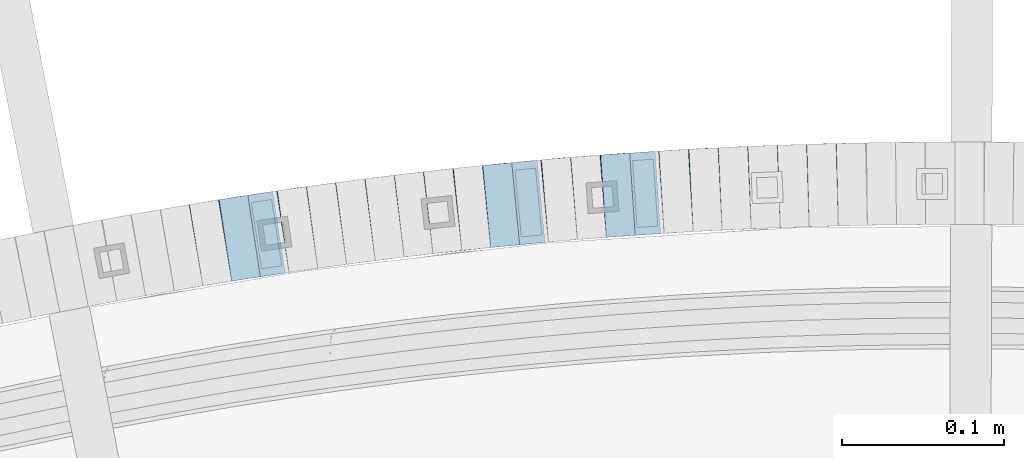
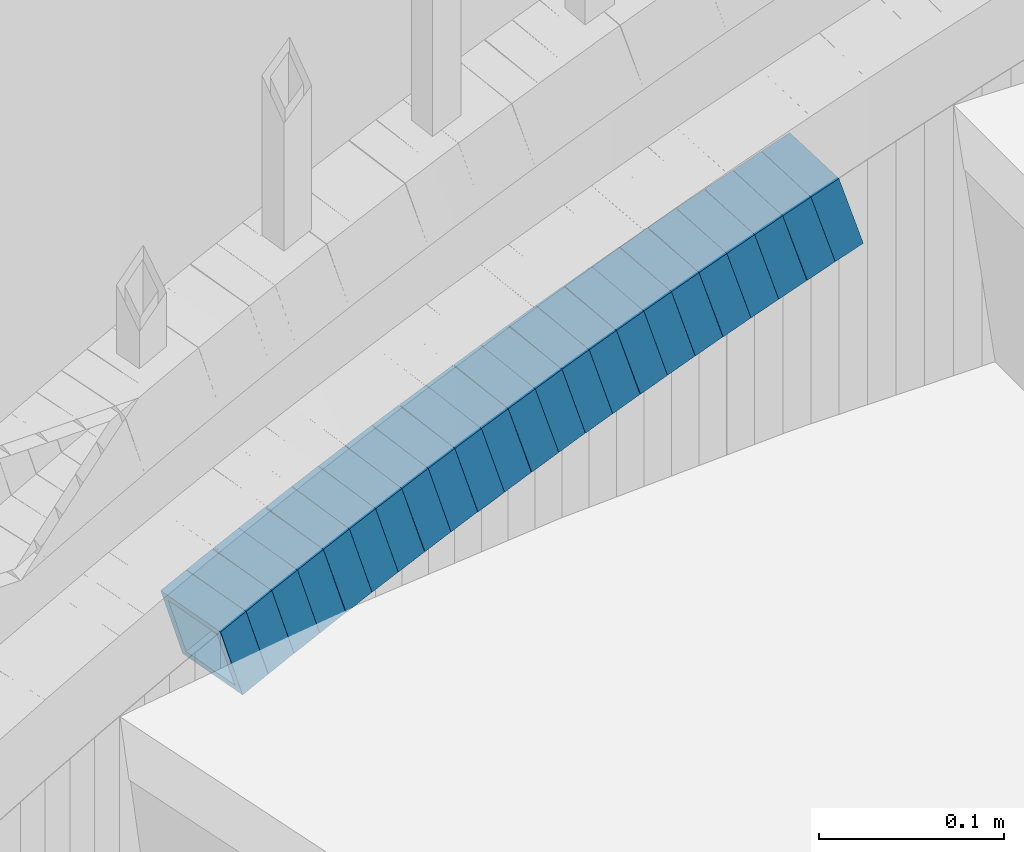
# One storey, part 817 of 975: 23 beams.
"""IFC2X3 building model written with IfcOpenShell, lengths in millimetres."""

from ifc_helpers import new_model, si_unit, frame, origin_with_axes, place, context, subcontext, project, spatial, faceted_brep, material, type_object, element, save


model = new_model("IFC2X3")

# Units and contexts
model_context = context("Model", 3, precision=1e-05, world=origin_with_axes())
body_context = subcontext(model_context, "Body", "Model", "MODEL_VIEW")
ifc_project = project(units=[si_unit("LENGTHUNIT", "METRE", prefix="MILLI"), si_unit("AREAUNIT", "SQUARE_METRE"), si_unit("VOLUMEUNIT", "CUBIC_METRE"), si_unit("MASSUNIT", "GRAM", prefix="KILO"), si_unit("TIMEUNIT", "SECOND"), si_unit("PLANEANGLEUNIT", "RADIAN"), si_unit("SOLIDANGLEUNIT", "STERADIAN"), si_unit("THERMODYNAMICTEMPERATUREUNIT", "DEGREE_CELSIUS"), si_unit("LUMINOUSINTENSITYUNIT", "LUMEN")], contexts=[model_context])

# Site, building, storey
site_placement = place(None, origin_with_axes())
site = spatial("IfcSite", under=ifc_project, at=site_placement, CompositionType="ELEMENT")
building_placement = place(site_placement, origin_with_axes())
building = spatial("IfcBuilding", under=site, at=building_placement, Name="Undefined", CompositionType="ELEMENT")
storey_placement = place(building_placement, origin_with_axes())
storey = spatial("IfcBuildingStorey", under=building, at=storey_placement, Name="Undefined", CompositionType="ELEMENT", Elevation=0.0)

# Beams
ifc_material = material()
beam_type = type_object("IfcBeamType", Name="HSS2X2X.188_TUBES", PredefinedType="NOTDEFINED")
beam_1_placement = place(storey_placement, frame((34651.9456916336, 6273.00545372927, 1013.93551160437), z_axis=(0.0335007382158728, -0.999438692736574, 7.27269480194081e-11), x_axis=(-0.950823807192718, -0.0318711890064746, -0.308088161062478)))
element("IfcBeam", 1, at=beam_1_placement, inside=storey, type_object=beam_type, material=ifc_material, Name="WALL", ObjectType="HSS2X2X.188_TUBES", context=body_context, shape_type="Brep", body=[
    faceted_brep([(0.0, 20.6374999999753, -20.6375000000298), (0.0, -20.6375000000153, -20.6375000000153), (18.8332159191086, -20.6374999999916, -20.6375000000153), (18.8332159190923, 20.6375000000062, -20.6375000000335), (0.0, -20.6374999999825, 20.6375000000335), (18.8332159191377, -20.6375000000062, 20.6375000000335), (0.0, 20.6375000000116, 20.6375000000189), (18.8332159191141, 20.6374999999916, 20.6375000000116), (0.0, 25.3999999999724, -25.4000000000342), (0.0, 25.400000000016, 25.4000000000196), (18.8332159191159, 25.3999999999905, 25.4000000000124), (18.8332159190886, 25.4000000000069, -25.4000000000415), (0.0, -25.399999999976, 25.4000000000378), (18.8332159191395, -25.4000000000069, 25.4000000000378), (0.0, -25.400000000016, -25.4000000000196), (18.8332159191104, -25.3999999999905, -25.400000000016)], [[[0, 1, 2, 3]], [[1, 4, 5, 2]], [[4, 6, 7, 5]], [[6, 0, 3, 7]], [[8, 9, 10, 11]], [[9, 12, 13, 10]], [[12, 14, 15, 13]], [[14, 8, 11, 15]], [[13, 15, 11, 10], [5, 7, 3, 2]], [[14, 12, 9, 8], [6, 4, 1, 0]]]),
])
beam_2_placement = place(storey_placement, frame((34669.8027725868, 6273.46496530648, 1019.60911814612), z_axis=(0.0280788118240962, -0.99960571243193, -6.01653482590336e-11), x_axis=(-0.952021405617887, -0.0267421739892645, -0.304860786877666)))
element("IfcBeam", 2, at=beam_2_placement, inside=storey, type_object=beam_type, material=ifc_material, Name="WALL", ObjectType="HSS2X2X.188_TUBES", context=body_context, shape_type="Brep", body=[
    faceted_brep([(0.0, 20.6374999999753, -20.6375000000298), (0.0, -20.6375000000153, -20.6375000000153), (18.6959888745805, -20.6374999999771, -20.6375000000407), (18.6959888746751, 20.637499999988, -20.6374999999716), (0.0, -20.6374999999825, 20.6375000000335), (18.6959888746969, -20.6375000000135, 20.6375000000371), (0.0, 20.6375000000116, 20.6375000000189), (18.6959888747988, 20.6374999999498, 20.6375000001062), (0.0, 25.3999999999724, -25.4000000000342), (0.0, 25.400000000016, 25.4000000000196), (18.695988874817, 25.3999999999414, 25.4000000001215), (18.6959888746678, 25.3999999999887, -25.399999999976), (0.0, -25.399999999976, 25.4000000000378), (18.6959888747042, -25.4000000000124, 25.4000000000378), (0.0, -25.400000000016, -25.4000000000196), (18.695988874555, -25.3999999999687, -25.4000000000597)], [[[0, 1, 2, 3]], [[1, 4, 5, 2]], [[4, 6, 7, 5]], [[6, 0, 3, 7]], [[8, 9, 10, 11]], [[9, 12, 13, 10]], [[12, 14, 15, 13]], [[14, 8, 11, 15]], [[13, 15, 11, 10], [5, 7, 3, 2]], [[14, 12, 9, 8], [6, 4, 1, 0]]]),
])
beam_3_placement = place(storey_placement, frame((34633.7787524898, 6272.43910339028, 1008.09576019962), z_axis=(0.0390762776090341, -0.999236230592257, 1.98711632037885e-10), x_axis=(-0.952195014016826, -0.0372366770006501, -0.303212937005408)))
element("IfcBeam", 3, at=beam_3_placement, inside=storey, type_object=beam_type, material=ifc_material, Name="WALL", ObjectType="HSS2X2X.188_TUBES", context=body_context, shape_type="Brep", body=[
    faceted_brep([(0.0, 20.6374999999753, -20.6375000000298), (0.0, -20.6375000000153, -20.6375000000153), (18.8047866246379, -20.6374999999916, -20.6375000000298), (18.8047866247143, 20.6374999999844, -20.6374999999643), (0.0, -20.6374999999825, 20.6375000000335), (18.8047866247107, -20.6375000000189, 20.6375000000407), (0.0, 20.6375000000116, 20.6375000000189), (18.8047866247907, 20.6374999999589, 20.6375000001026), (0.0, 25.3999999999724, -25.4000000000342), (0.0, 25.400000000016, 25.4000000000196), (18.8047866248016, 25.3999999999542, 25.4000000001142), (18.8047866247143, 25.3999999999851, -25.3999999999651), (0.0, -25.399999999976, 25.4000000000378), (18.8047866247107, -25.4000000000196, 25.4000000000415), (0.0, -25.400000000016, -25.4000000000196), (18.8047866246197, -25.3999999999887, -25.4000000000378)], [[[0, 1, 2, 3]], [[1, 4, 5, 2]], [[4, 6, 7, 5]], [[6, 0, 3, 7]], [[8, 9, 10, 11]], [[9, 12, 13, 10]], [[12, 14, 15, 13]], [[14, 8, 11, 15]], [[13, 15, 11, 10], [5, 7, 3, 2]], [[14, 12, 9, 8], [6, 4, 1, 0]]]),
])
beam_4_placement = place(storey_placement, frame((34615.766485447, 6271.77941453297, 1002.40773709342), z_axis=(0.044898496675909, -0.998991554016471, 2.07617631531321e-10), x_axis=(-0.951490800323589, -0.0427636310145619, -0.304690874103617)))
element("IfcBeam", 4, at=beam_4_placement, inside=storey, type_object=beam_type, material=ifc_material, Name="WALL", ObjectType="HSS2X2X.188_TUBES", context=body_context, shape_type="Brep", body=[
    faceted_brep([(0.0, 20.6374999999753, -20.6375000000298), (0.0, -20.6375000000153, -20.6375000000153), (18.7112265765609, -20.6375000000062, -20.6374999999862), (18.7112265765645, 20.6374999999898, -20.6374999999789), (0.0, -20.6374999999825, 20.6375000000335), (18.7112265765209, -20.6374999999916, 20.6374999999607), (0.0, 20.6375000000116, 20.6375000000189), (18.7112265765245, 20.6375000000025, 20.6374999999716), (0.0, 25.3999999999724, -25.4000000000342), (0.0, 25.400000000016, 25.4000000000196), (18.7112265765172, 25.4000000000051, 25.3999999999614), (18.7112265765718, 25.3999999999887, -25.3999999999724), (0.0, -25.399999999976, 25.4000000000378), (18.7112265765136, -25.3999999999905, 25.3999999999542), (0.0, -25.400000000016, -25.4000000000196), (18.7112265765682, -25.4000000000069, -25.3999999999796)], [[[0, 1, 2, 3]], [[1, 4, 5, 2]], [[4, 6, 7, 5]], [[6, 0, 3, 7]], [[8, 9, 10, 11]], [[9, 12, 13, 10]], [[12, 14, 15, 13]], [[14, 8, 11, 15]], [[13, 15, 11, 10], [5, 7, 3, 2]], [[14, 12, 9, 8], [6, 4, 1, 0]]]),
])
beam_5_placement = place(storey_placement, frame((34597.9106893534, 6271.01822015742, 996.733904844898), z_axis=(0.0502158966098432, -0.998738386028929, -1.26572444969497e-10), x_axis=(-0.950220743318218, -0.04777646201599, -0.307892755103149)))
element("IfcBeam", 5, at=beam_5_placement, inside=storey, type_object=beam_type, material=ifc_material, Name="WALL", ObjectType="HSS2X2X.188_TUBES", context=body_context, shape_type="Brep", body=[
    faceted_brep([(0.0, 20.6374999999753, -20.6375000000298), (0.0, -20.6375000000153, -20.6375000000153), (18.8433011969464, -20.6374999999898, -20.6375000000226), (18.8433011969719, 20.6375000000007, -20.6374999999862), (0.0, -20.6374999999825, 20.6375000000335), (18.8433011969828, -20.6375000000044, 20.6375000000189), (0.0, 20.6375000000116, 20.6375000000189), (18.8433011970155, 20.6374999999862, 20.6375000000517), (0.0, 25.3999999999724, -25.4000000000342), (0.0, 25.400000000016, 25.4000000000196), (18.8433011970228, 25.3999999999833, 25.4000000000597), (18.8433011969719, 25.4000000000015, -25.3999999999869), (0.0, -25.399999999976, 25.4000000000378), (18.8433011969864, -25.4000000000051, 25.4000000000196), (0.0, -25.400000000016, -25.4000000000196), (18.8433011969391, -25.3999999999869, -25.4000000000269)], [[[0, 1, 2, 3]], [[1, 4, 5, 2]], [[4, 6, 7, 5]], [[6, 0, 3, 7]], [[8, 9, 10, 11]], [[9, 12, 13, 10]], [[12, 14, 15, 13]], [[14, 8, 11, 15]], [[13, 15, 11, 10], [5, 7, 3, 2]], [[14, 12, 9, 8], [6, 4, 1, 0]]]),
])
beam_6_placement = place(storey_placement, frame((34579.6270192323, 6270.18615367943, 990.905724300762), z_axis=(0.0616800884415425, -0.998095970681098, 1.47142372952658e-10), x_axis=(-0.950716893774198, -0.058752167986055, -0.304443049927697)))
element("IfcBeam", 6, at=beam_6_placement, inside=storey, type_object=beam_type, material=ifc_material, Name="WALL", ObjectType="HSS2X2X.188_TUBES", context=body_context, shape_type="Brep", body=[
    faceted_brep([(0.0, 20.6374999999753, -20.6375000000298), (0.0, -20.6375000000153, -20.6375000000153), (18.724849799155, -20.6375000000171, -20.6374999999425), (18.7248497991204, 20.6374999999989, -20.6375000000007), (0.0, -20.6374999999825, 20.6375000000335), (18.7248497991168, -20.6374999999953, 20.6375000000007), (0.0, 20.6375000000116, 20.6375000000189), (18.724849799084, 20.6375000000226, 20.6374999999498), (0.0, 25.3999999999724, -25.4000000000342), (0.0, 25.400000000016, 25.4000000000196), (18.7248497990731, 25.4000000000269, 25.399999999936), (18.7248497991204, 25.3999999999978, -25.3999999999978), (0.0, -25.399999999976, 25.4000000000378), (18.7248497991186, -25.3999999999942, 25.4000000000051), (0.0, -25.400000000016, -25.4000000000196), (18.7248497991604, -25.4000000000233, -25.3999999999323)], [[[0, 1, 2, 3]], [[1, 4, 5, 2]], [[4, 6, 7, 5]], [[6, 0, 3, 7]], [[8, 9, 10, 11]], [[9, 12, 13, 10]], [[12, 14, 15, 13]], [[14, 8, 11, 15]], [[13, 15, 11, 10], [5, 7, 3, 2]], [[14, 12, 9, 8], [6, 4, 1, 0]]]),
])
beam_7_placement = place(storey_placement, frame((34561.6506361358, 6269.11512934846, 985.19247535075), z_axis=(0.0668889670804565, -0.997760425193799, 2.13868815990281e-11), x_axis=(-0.950917720470324, -0.0637486740315266, -0.302806201149754)))
element("IfcBeam", 7, at=beam_7_placement, inside=storey, type_object=beam_type, material=ifc_material, Name="WALL", ObjectType="HSS2X2X.188_TUBES", context=body_context, shape_type="Brep", body=[
    faceted_brep([(0.0, 20.6374999999753, -20.6375000000298), (0.0, -20.6375000000153, -20.6375000000153), (18.8225928075335, -20.6374999999935, -20.6375000000298), (18.8225928075699, 20.6374999999898, -20.6374999999825), (0.0, -20.6374999999825, 20.6375000000335), (18.8225928075772, -20.637500000008, 20.6375000000226), (0.0, 20.6375000000116, 20.6375000000189), (18.8225928076135, 20.6374999999753, 20.6375000000698), (0.0, 25.3999999999724, -25.4000000000342), (0.0, 25.400000000016, 25.4000000000196), (18.8225928076281, 25.3999999999705, 25.4000000000815), (18.8225928075663, 25.3999999999905, -25.3999999999796), (0.0, -25.399999999976, 25.4000000000378), (18.8225928075808, -25.4000000000087, 25.4000000000233), (0.0, -25.400000000016, -25.4000000000196), (18.8225928075226, -25.3999999999905, -25.4000000000378)], [[[0, 1, 2, 3]], [[1, 4, 5, 2]], [[4, 6, 7, 5]], [[6, 0, 3, 7]], [[8, 9, 10, 11]], [[9, 12, 13, 10]], [[12, 14, 15, 13]], [[14, 8, 11, 15]], [[13, 15, 11, 10], [5, 7, 3, 2]], [[14, 12, 9, 8], [6, 4, 1, 0]]]),
])
beam_8_placement = place(storey_placement, frame((34543.9023718288, 6267.9282507441, 979.544478576939), z_axis=(0.0672630522607651, -0.997735276413822, -1.4846455087536e-10), x_axis=(-0.948851018029333, -0.0639674840019559, -0.309176174009509)))
element("IfcBeam", 8, at=beam_8_placement, inside=storey, type_object=beam_type, material=ifc_material, Name="WALL", ObjectType="HSS2X2X.188_TUBES", context=body_context, shape_type="Brep", body=[
    faceted_brep([(0.0, 20.6374999999753, -20.6375000000298), (0.0, -20.6375000000153, -20.6375000000153), (18.7555325170906, -20.6374999999916, -20.6374999999971), (18.7555325171452, 20.637499999988, -20.6374999999571), (0.0, -20.6374999999825, 20.6375000000335), (18.7555325170615, -20.6374999999844, 20.6374999999716), (0.0, 20.6375000000116, 20.6375000000189), (18.7555325171015, 20.6374999999953, 20.637500000008), (0.0, 25.3999999999724, -25.4000000000342), (0.0, 25.400000000016, 25.4000000000196), (18.7555325171015, 25.399999999996, 25.4000000000051), (18.7555325171488, 25.3999999999851, -25.3999999999505), (0.0, -25.399999999976, 25.4000000000378), (18.755532517047, -25.3999999999814, 25.3999999999578), (0.0, -25.400000000016, -25.4000000000196), (18.7555325170979, -25.3999999999924, -25.3999999999978)], [[[0, 1, 2, 3]], [[1, 4, 5, 2]], [[4, 6, 7, 5]], [[6, 0, 3, 7]], [[8, 9, 10, 11]], [[9, 12, 13, 10]], [[12, 14, 15, 13]], [[14, 8, 11, 15]], [[13, 15, 11, 10], [5, 7, 3, 2]], [[14, 12, 9, 8], [6, 4, 1, 0]]]),
])
beam_9_placement = place(storey_placement, frame((34525.6847734434, 6266.78503410578, 973.703086094591), z_axis=(0.0784095351745709, -0.996921232993714, -1.11433109850623e-10), x_axis=(-0.949701466907197, -0.074695620992727, -0.304117884970335)))
element("IfcBeam", 9, at=beam_9_placement, inside=storey, type_object=beam_type, material=ifc_material, Name="WALL", ObjectType="HSS2X2X.188_TUBES", context=body_context, shape_type="Brep", body=[
    faceted_brep([(0.0, 20.6374999999753, -20.6375000000298), (0.0, -20.6375000000153, -20.6375000000153), (18.7416648140024, -20.6375000000153, -20.6374999999825), (18.7416648139188, 20.6375000000189, -20.6375000000298), (0.0, -20.6374999999825, 20.6375000000335), (18.7416648140097, -20.6375000000189, 20.6375000000226), (0.0, 20.6375000000116, 20.6375000000189), (18.741664813926, 20.6375000000153, 20.6374999999753), (0.0, 25.3999999999724, -25.4000000000342), (0.0, 25.400000000016, 25.4000000000196), (18.7416648139224, 25.4000000000196, 25.3999999999687), (18.7416648139042, 25.4000000000233, -25.4000000000378), (0.0, -25.399999999976, 25.4000000000378), (18.7416648140133, -25.4000000000215, 25.4000000000269), (0.0, -25.400000000016, -25.4000000000196), (18.7416648140133, -25.4000000000196, -25.399999999976)], [[[0, 1, 2, 3]], [[1, 4, 5, 2]], [[4, 6, 7, 5]], [[6, 0, 3, 7]], [[8, 9, 10, 11]], [[9, 12, 13, 10]], [[12, 14, 15, 13]], [[14, 8, 11, 15]], [[13, 15, 11, 10], [5, 7, 3, 2]], [[14, 12, 9, 8], [6, 4, 1, 0]]]),
])
beam_10_placement = place(storey_placement, frame((34507.7368106391, 6265.41622528425, 968.002069082572), z_axis=(0.0839720319663757, -0.996468111806614, -5.50892309547635e-12), x_axis=(-0.949309706342206, -0.0799980090288675, -0.30399243410962)))
element("IfcBeam", 10, at=beam_10_placement, inside=storey, type_object=beam_type, material=ifc_material, Name="WALL", ObjectType="HSS2X2X.188_TUBES", context=body_context, shape_type="Brep", body=[
    faceted_brep([(0.0, 20.6374999999753, -20.6375000000298), (0.0, -20.6375000000153, -20.6375000000153), (18.7547327359644, -20.6374999999844, -20.6375000000553), (18.7547327359898, 20.6375000000171, -20.6375000000335), (0.0, -20.6374999999825, 20.6375000000335), (18.7547327360044, -20.6374999999953, 20.6374999999898), (0.0, 20.6375000000116, 20.6375000000189), (18.7547327360262, 20.6375000000062, 20.6375000000116), (0.0, 25.3999999999724, -25.4000000000342), (0.0, 25.400000000016, 25.4000000000196), (18.7547327360371, 25.4000000000033, 25.4000000000124), (18.7547327359898, 25.4000000000178, -25.4000000000342), (0.0, -25.399999999976, 25.4000000000378), (18.7547327360044, -25.399999999996, 25.3999999999869), (0.0, -25.400000000016, -25.4000000000196), (18.7547327359498, -25.3999999999814, -25.4000000000597)], [[[0, 1, 2, 3]], [[1, 4, 5, 2]], [[4, 6, 7, 5]], [[6, 0, 3, 7]], [[8, 9, 10, 11]], [[9, 12, 13, 10]], [[12, 14, 15, 13]], [[14, 8, 11, 15]], [[13, 15, 11, 10], [5, 7, 3, 2]], [[14, 12, 9, 8], [6, 4, 1, 0]]]),
])
beam_11_placement = place(storey_placement, frame((34489.6652361008, 6263.98248508332, 962.312352926034), z_axis=(0.0956052464452733, -0.995419327144163, 1.37664756039158e-10), x_axis=(-0.947907534808342, -0.0910419669816018, -0.305258358938281)))
element("IfcBeam", 11, at=beam_11_placement, inside=storey, type_object=beam_type, material=ifc_material, Name="WALL", ObjectType="HSS2X2X.188_TUBES", context=body_context, shape_type="Brep", body=[
    faceted_brep([(0.0, 20.6374999999753, -20.6375000000298), (0.0, -20.6375000000153, -20.6375000000153), (18.6689581926366, -20.6374999999953, -20.6374999999916), (18.6689581926476, 20.6375000000062, -20.6374999999935), (0.0, -20.6374999999825, 20.6375000000335), (18.6689581927276, -20.6375000000116, 20.6374999999862), (0.0, 20.6375000000116, 20.6375000000189), (18.6689581927312, 20.6374999999862, 20.6374999999844), (0.0, 25.3999999999724, -25.4000000000342), (0.0, 25.400000000016, 25.4000000000196), (18.6689581927458, 25.3999999999833, 25.3999999999814), (18.6689581926366, 25.4000000000087, -25.3999999999905), (0.0, -25.399999999976, 25.4000000000378), (18.6689581927385, -25.4000000000142, 25.3999999999851), (0.0, -25.400000000016, -25.4000000000196), (18.6689581926257, -25.3999999999887, -25.3999999999869)], [[[0, 1, 2, 3]], [[1, 4, 5, 2]], [[4, 6, 7, 5]], [[6, 0, 3, 7]], [[8, 9, 10, 11]], [[9, 12, 13, 10]], [[12, 14, 15, 13]], [[14, 8, 11, 15]], [[13, 15, 11, 10], [5, 7, 3, 2]], [[14, 12, 9, 8], [6, 4, 1, 0]]]),
])
beam_12_placement = place(storey_placement, frame((34472.062156533, 6262.28758067493, 956.639241073771), z_axis=(0.0950730065790558, -0.995470302630882, 1.98357952285733e-10), x_axis=(-0.946902283782594, -0.090434487979261, -0.308541193929169)))
element("IfcBeam", 12, at=beam_12_placement, inside=storey, type_object=beam_type, material=ifc_material, Name="WALL", ObjectType="HSS2X2X.188_TUBES", context=body_context, shape_type="Brep", body=[
    faceted_brep([(0.0, 20.6374999999753, -20.6375000000298), (0.0, -20.6375000000153, -20.6375000000153), (18.8047866246379, -20.6374999999916, -20.6375000000298), (18.8047866247143, 20.6374999999844, -20.6374999999643), (0.0, -20.6374999999825, 20.6375000000335), (18.8047866247107, -20.6375000000189, 20.6375000000407), (0.0, 20.6375000000116, 20.6375000000189), (18.8047866247907, 20.6374999999589, 20.6375000001026), (0.0, 25.3999999999724, -25.4000000000342), (0.0, 25.400000000016, 25.4000000000196), (18.8047866248016, 25.3999999999542, 25.4000000001142), (18.8047866247143, 25.3999999999851, -25.3999999999651), (0.0, -25.399999999976, 25.4000000000378), (18.8047866247107, -25.4000000000196, 25.4000000000415), (0.0, -25.400000000016, -25.4000000000196), (18.8047866246197, -25.3999999999887, -25.4000000000378)], [[[0, 1, 2, 3]], [[1, 4, 5, 2]], [[4, 6, 7, 5]], [[6, 0, 3, 7]], [[8, 9, 10, 11]], [[9, 12, 13, 10]], [[12, 14, 15, 13]], [[14, 8, 11, 15]], [[13, 15, 11, 10], [5, 7, 3, 2]], [[14, 12, 9, 8], [6, 4, 1, 0]]]),
])
beam_13_placement = place(storey_placement, frame((34453.842627824, 6260.63203614672, 950.797322509361), z_axis=(0.10613862675189, -0.994351342288641, 2.283063622599e-10), x_axis=(-0.947478931466088, -0.101135391943018, -0.303406174829077)))
element("IfcBeam", 13, at=beam_13_placement, inside=storey, type_object=beam_type, material=ifc_material, Name="WALL", ObjectType="HSS2X2X.188_TUBES", context=body_context, shape_type="Brep", body=[
    faceted_brep([(0.0, 20.6374999999753, -20.6375000000298), (0.0, -20.6375000000153, -20.6375000000153), (18.7853666454903, -20.6375000000535, -20.6375000000326), (18.785366645363, 20.6374999999862, -20.6375000000044), (0.0, -20.6374999999825, 20.6375000000335), (18.785366645352, -20.6375000000007, 20.6374999999989), (0.0, 20.6375000000116, 20.6375000000189), (18.7853666453102, 20.6375000000025, 20.6374999999753), (0.0, 25.3999999999724, -25.4000000000342), (0.0, 25.400000000016, 25.4000000000196), (18.7853666452065, 25.4000000000451, 25.4000000000351), (18.7853666453739, 25.3999999999833, -25.400000000006), (0.0, -25.399999999976, 25.4000000000378), (18.7853666497213, -25.399999993424, 25.3999999995158), (0.0, -25.400000000016, -25.4000000000196), (18.7853666455194, -25.4000000000633, -25.4000000000406)], [[[0, 1, 2, 3]], [[1, 4, 5, 2]], [[4, 6, 7, 5]], [[6, 0, 3, 7]], [[8, 9, 10, 11]], [[9, 12, 13, 10]], [[12, 14, 15, 13]], [[14, 8, 11, 15]], [[13, 15, 11, 10], [5, 7, 3, 2]], [[14, 12, 9, 8], [6, 4, 1, 0]]]),
])
beam_14_placement = place(storey_placement, frame((34436.0659098705, 6258.739161128, 945.109792112416), z_axis=(0.106731467305151, -0.994287882802003, -2.14448618862662e-10), x_axis=(-0.946930338465762, -0.101647889050003, -0.30494366815003)))
element("IfcBeam", 14, at=beam_14_placement, inside=storey, type_object=beam_type, material=ifc_material, Name="WALL", ObjectType="HSS2X2X.188_TUBES", context=body_context, shape_type="Brep", body=[
    faceted_brep([(0.0, 20.6374999999753, -20.6375000000298), (0.0, -20.6375000000153, -20.6375000000153), (18.6895692834223, -20.637499999988, -20.6374999999862), (18.6895692834369, 20.6374999999953, -20.6374999999534), (0.0, -20.6374999999825, 20.6375000000335), (18.6895692833914, -20.637499999988, 20.6374999999789), (0.0, 20.6375000000116, 20.6375000000189), (18.6895692834078, 20.6374999999953, 20.637500000008), (0.0, 25.3999999999724, -25.4000000000342), (0.0, 25.400000000016, 25.4000000000196), (18.6895692834059, 25.3999999999924, 25.4000000000087), (18.6895692834423, 25.3999999999942, -25.3999999999432), (0.0, -25.399999999976, 25.4000000000378), (18.6895692833878, -25.3999999999869, 25.3999999999687), (0.0, -25.400000000016, -25.4000000000196), (18.6895692834241, -25.3999999999869, -25.3999999999833)], [[[0, 1, 2, 3]], [[1, 4, 5, 2]], [[4, 6, 7, 5]], [[6, 0, 3, 7]], [[8, 9, 10, 11]], [[9, 12, 13, 10]], [[12, 14, 15, 13]], [[14, 8, 11, 15]], [[13, 15, 11, 10], [5, 7, 3, 2]], [[14, 12, 9, 8], [6, 4, 1, 0]]]),
])
beam_15_placement = place(storey_placement, frame((34418.0443524869, 6256.88452171945, 939.394547887718), z_axis=(0.117164953610445, -0.99311246777264, -1.14560293695831e-10), x_axis=(-0.946406940559033, -0.111654750947977, -0.303062896858783)))
element("IfcBeam", 15, at=beam_15_placement, inside=storey, type_object=beam_type, material=ifc_material, Name="WALL", ObjectType="HSS2X2X.188_TUBES", context=body_context, shape_type="Brep", body=[
    faceted_brep([(0.0, 20.6374999999753, -20.6375000000298), (0.0, -20.6375000000153, -20.6375000000153), (18.8066477608099, -20.6374999999862, -20.6375000000116), (18.8066477608172, 20.6375000000062, -20.6374999999971), (0.0, -20.6374999999825, 20.6375000000335), (18.8066477608463, -20.6375000000062, 20.6375000000407), (0.0, 20.6375000000116, 20.6375000000189), (18.8066477608536, 20.6374999999844, 20.637500000048), (0.0, 25.3999999999724, -25.4000000000342), (0.0, 25.400000000016, 25.4000000000196), (18.8066477608591, 25.3999999999814, 25.400000000056), (18.8066477608154, 25.4000000000051, -25.4000000000015), (0.0, -25.399999999976, 25.4000000000378), (18.8066477608518, -25.4000000000087, 25.4000000000451), (0.0, -25.400000000016, -25.4000000000196), (18.8066477608081, -25.3999999999851, -25.4000000000196)], [[[0, 1, 2, 3]], [[1, 4, 5, 2]], [[4, 6, 7, 5]], [[6, 0, 3, 7]], [[8, 9, 10, 11]], [[9, 12, 13, 10]], [[12, 14, 15, 13]], [[14, 8, 11, 15]], [[13, 15, 11, 10], [5, 7, 3, 2]], [[14, 12, 9, 8], [6, 4, 1, 0]]]),
])
beam_16_placement = place(storey_placement, frame((34400.2373783662, 6254.83243716997, 933.745022917291), z_axis=(0.123344664337586, -0.992363891815622, -2.0636423414544e-10), x_axis=(-0.943721538367308, -0.117298722045678, -0.309242086120394)))
element("IfcBeam", 16, at=beam_16_placement, inside=storey, type_object=beam_type, material=ifc_material, Name="WALL", ObjectType="HSS2X2X.188_TUBES", context=body_context, shape_type="Brep", body=[
    faceted_brep([(0.0, 20.6374999999753, -20.6375000000298), (0.0, -20.6375000000153, -20.6375000000153), (18.7555325170906, -20.6374999999916, -20.6374999999971), (18.7555325171452, 20.637499999988, -20.6374999999571), (0.0, -20.6374999999825, 20.6375000000335), (18.7555325170615, -20.6374999999844, 20.6374999999716), (0.0, 20.6375000000116, 20.6375000000189), (18.7555325171015, 20.6374999999953, 20.637500000008), (0.0, 25.3999999999724, -25.4000000000342), (0.0, 25.400000000016, 25.4000000000196), (18.7555325171015, 25.399999999996, 25.4000000000051), (18.7555325171488, 25.3999999999851, -25.3999999999505), (0.0, -25.399999999976, 25.4000000000378), (18.755532517047, -25.3999999999814, 25.3999999999578), (0.0, -25.400000000016, -25.4000000000196), (18.7555325170979, -25.3999999999924, -25.3999999999978)], [[[0, 1, 2, 3]], [[1, 4, 5, 2]], [[4, 6, 7, 5]], [[6, 0, 3, 7]], [[8, 9, 10, 11]], [[9, 12, 13, 10]], [[12, 14, 15, 13]], [[14, 8, 11, 15]], [[13, 15, 11, 10], [5, 7, 3, 2]], [[14, 12, 9, 8], [6, 4, 1, 0]]]),
])
beam_17_placement = place(storey_placement, frame((34382.265108553, 6252.64149160385, 927.903858770483), z_axis=(0.128860134810282, -0.991662778194622, -6.80902303429321e-11), x_axis=(-0.944661915133941, -0.122752678017422, -0.304213159043171)))
element("IfcBeam", 17, at=beam_17_placement, inside=storey, type_object=beam_type, material=ifc_material, Name="WALL", ObjectType="HSS2X2X.188_TUBES", context=body_context, shape_type="Brep", body=[
    faceted_brep([(0.0, 20.6374999999753, -20.6375000000298), (0.0, -20.6375000000153, -20.6375000000153), (18.7416648140024, -20.6375000000153, -20.6374999999825), (18.7416648139188, 20.6375000000189, -20.6375000000298), (0.0, -20.6374999999825, 20.6375000000335), (18.7416648140097, -20.6375000000189, 20.6375000000226), (0.0, 20.6375000000116, 20.6375000000189), (18.741664813926, 20.6375000000153, 20.6374999999753), (0.0, 25.3999999999724, -25.4000000000342), (0.0, 25.400000000016, 25.4000000000196), (18.7416648139224, 25.4000000000196, 25.3999999999687), (18.7416648139042, 25.4000000000233, -25.4000000000378), (0.0, -25.399999999976, 25.4000000000378), (18.7416648140133, -25.4000000000215, 25.4000000000269), (0.0, -25.400000000016, -25.4000000000196), (18.7416648140133, -25.4000000000196, -25.399999999976)], [[[0, 1, 2, 3]], [[1, 4, 5, 2]], [[4, 6, 7, 5]], [[6, 0, 3, 7]], [[8, 9, 10, 11]], [[9, 12, 13, 10]], [[12, 14, 15, 13]], [[14, 8, 11, 15]], [[13, 15, 11, 10], [5, 7, 3, 2]], [[14, 12, 9, 8], [6, 4, 1, 0]]]),
])
beam_18_placement = place(storey_placement, frame((34364.4145523541, 6250.36476371868, 922.202209257951), z_axis=(0.134363672851374, -0.990932088196708, -5.54322241441696e-11), x_axis=(-0.944030209558849, -0.128004096075804, -0.304009728180024)))
element("IfcBeam", 18, at=beam_18_placement, inside=storey, type_object=beam_type, material=ifc_material, Name="WALL", ObjectType="HSS2X2X.188_TUBES", context=body_context, shape_type="Brep", body=[
    faceted_brep([(0.0, 20.6374999999753, -20.6375000000298), (0.0, -20.6375000000153, -20.6375000000153), (18.7547327359644, -20.6374999999844, -20.6375000000553), (18.7547327359898, 20.6375000000171, -20.6375000000335), (0.0, -20.6374999999825, 20.6375000000335), (18.7547327360044, -20.6374999999953, 20.6374999999898), (0.0, 20.6375000000116, 20.6375000000189), (18.7547327360262, 20.6375000000062, 20.6375000000116), (0.0, 25.3999999999724, -25.4000000000342), (0.0, 25.400000000016, 25.4000000000196), (18.7547327360371, 25.4000000000033, 25.4000000000124), (18.7547327359898, 25.4000000000178, -25.4000000000342), (0.0, -25.399999999976, 25.4000000000378), (18.7547327360044, -25.399999999996, 25.3999999999869), (0.0, -25.400000000016, -25.4000000000196), (18.7547327359498, -25.3999999999814, -25.4000000000597)], [[[0, 1, 2, 3]], [[1, 4, 5, 2]], [[4, 6, 7, 5]], [[6, 0, 3, 7]], [[8, 9, 10, 11]], [[9, 12, 13, 10]], [[12, 14, 15, 13]], [[14, 8, 11, 15]], [[13, 15, 11, 10], [5, 7, 3, 2]], [[14, 12, 9, 8], [6, 4, 1, 0]]]),
])
for number, where, z_axis, x_axis, name in (
    (19, (34346.6852635197, 6248.00425168112, 916.539924854585), (0.139854805609604, -0.99017202209914, 1.91350977729599e-10), (-0.941835845386855, -0.133027662054669, -0.308624175126798), "WALL"),
    (20, (34328.5622816918, 6245.52900703326, 910.696870756206), (0.150797989337363, -0.98856459900798, -2.08921846933663e-10), (-0.941982549776798, -0.14369225296596, -0.303350312928089), "WALL"),
):
    element("IfcBeam", number, at=place(storey_placement, frame(where, z_axis=z_axis, x_axis=x_axis)), inside=storey, type_object=beam_type, material=ifc_material, Name=name, ObjectType="HSS2X2X.188_TUBES", context=body_context, shape_type="Brep", body=[
        faceted_brep([(0.0, 20.6374999999753, -20.6375000000298), (0.0, -20.6375000000153, -20.6375000000153), (18.7853666454903, -20.6375000000535, -20.6375000000326), (18.785366645363, 20.6374999999862, -20.6375000000044), (0.0, -20.6374999999825, 20.6375000000335), (18.785366645352, -20.6375000000007, 20.6374999999989), (0.0, 20.6375000000116, 20.6375000000189), (18.7853666453102, 20.6375000000025, 20.6374999999753), (0.0, 25.3999999999724, -25.4000000000342), (0.0, 25.400000000016, 25.4000000000196), (18.7853666452065, 25.4000000000451, 25.4000000000351), (18.7853666453739, 25.3999999999833, -25.400000000006), (0.0, -25.399999999976, 25.4000000000378), (18.7853666497213, -25.399999993424, 25.3999999995158), (0.0, -25.400000000016, -25.4000000000196), (18.7853666455194, -25.4000000000633, -25.4000000000406)], [[[0, 1, 2, 3]], [[1, 4, 5, 2]], [[4, 6, 7, 5]], [[6, 0, 3, 7]], [[8, 9, 10, 11]], [[9, 12, 13, 10]], [[12, 14, 15, 13]], [[14, 8, 11, 15]], [[13, 15, 11, 10], [5, 7, 3, 2]], [[14, 12, 9, 8], [6, 4, 1, 0]]]),
    ])
beam_19_placement = place(storey_placement, frame((34293.0811005359, 6240.18695346071, 899.332195571267), z_axis=(0.161686018393273, -0.986842252569341, -1.71101078194624e-10), x_axis=(-0.938968920147763, -0.153842365024199, -0.307684731048366)))
element("IfcBeam", 21, at=beam_19_placement, inside=storey, type_object=beam_type, material=ifc_material, Name="WALL", ObjectType="HSS2X2X.188_TUBES", context=body_context, shape_type="Brep", body=[
    faceted_brep([(0.0, 20.6374999999753, -20.6375000000298), (0.0, -20.6375000000153, -20.6375000000153), (18.8480768248774, -20.6374999999716, -20.6375000000735), (18.8480768249356, 20.6375000000153, -20.6375000000226), (0.0, -20.6374999999825, 20.6375000000335), (18.8480768249283, -20.6374999999935, 20.6374999999716), (0.0, 20.6375000000116, 20.6375000000189), (18.8480768249865, 20.6374999999935, 20.6375000000262), (0.0, 25.3999999999724, -25.4000000000342), (0.0, 25.400000000016, 25.4000000000196), (18.848076825001, 25.3999999999887, 25.4000000000378), (18.8480768249392, 25.4000000000142, -25.4000000000233), (0.0, -25.399999999976, 25.4000000000378), (18.8480768249283, -25.399999999996, 25.3999999999833), (0.0, -25.400000000016, -25.4000000000196), (18.8480768248664, -25.3999999999687, -25.4000000000779)], [[[0, 1, 2, 3]], [[1, 4, 5, 2]], [[4, 6, 7, 5]], [[6, 0, 3, 7]], [[8, 9, 10, 11]], [[9, 12, 13, 10]], [[12, 14, 15, 13]], [[14, 8, 11, 15]], [[13, 15, 11, 10], [5, 7, 3, 2]], [[14, 12, 9, 8], [6, 4, 1, 0]]]),
])
beam_20_placement = place(storey_placement, frame((34310.878391401, 6242.83808940459, 905.009259971618), z_axis=(0.151635150261849, -0.988436533726403, 9.61329078563721e-11), x_axis=(-0.941378395041392, -0.144416004006362, -0.304878230013441)))
element("IfcBeam", 22, at=beam_20_placement, inside=storey, type_object=beam_type, material=ifc_material, Name="WALL", ObjectType="HSS2X2X.188_TUBES", context=body_context, shape_type="Brep", body=[
    faceted_brep([(0.0, 20.6374999999753, -20.6375000000298), (0.0, -20.6375000000153, -20.6375000000153), (18.6959888745805, -20.6374999999771, -20.6375000000407), (18.6959888746751, 20.637499999988, -20.6374999999716), (0.0, -20.6374999999825, 20.6375000000335), (18.6959888746969, -20.6375000000135, 20.6375000000371), (0.0, 20.6375000000116, 20.6375000000189), (18.6959888747988, 20.6374999999498, 20.6375000001062), (0.0, 25.3999999999724, -25.4000000000342), (0.0, 25.400000000016, 25.4000000000196), (18.695988874817, 25.3999999999414, 25.4000000001215), (18.6959888746678, 25.3999999999887, -25.399999999976), (0.0, -25.399999999976, 25.4000000000378), (18.6959888747042, -25.4000000000124, 25.4000000000378), (0.0, -25.400000000016, -25.4000000000196), (18.695988874555, -25.3999999999687, -25.4000000000597)], [[[0, 1, 2, 3]], [[1, 4, 5, 2]], [[4, 6, 7, 5]], [[6, 0, 3, 7]], [[8, 9, 10, 11]], [[9, 12, 13, 10]], [[12, 14, 15, 13]], [[14, 8, 11, 15]], [[13, 15, 11, 10], [5, 7, 3, 2]], [[14, 12, 9, 8], [6, 4, 1, 0]]]),
])
beam_21_placement = place(storey_placement, frame((34275.1227742085, 6237.29445353575, 893.503226507557), z_axis=(0.168030974737259, -0.985781715963958, 2.33963987739117e-10), x_axis=(-0.939084130164932, -0.160071159028104, -0.304135201053369)))
element("IfcBeam", 23, at=beam_21_placement, inside=storey, type_object=beam_type, material=ifc_material, Name="WALL", ObjectType="HSS2X2X.188_TUBES", context=body_context, shape_type="Brep", body=[
    faceted_brep([(0.0, 20.6374999999753, -20.6375000000298), (0.0, -20.6375000000153, -20.6375000000153), (18.7416648140024, -20.6375000000153, -20.6374999999825), (18.7416648139188, 20.6375000000189, -20.6375000000298), (0.0, -20.6374999999825, 20.6375000000335), (18.7416648140097, -20.6375000000189, 20.6375000000226), (0.0, 20.6375000000116, 20.6375000000189), (18.741664813926, 20.6375000000153, 20.6374999999753), (0.0, 25.3999999999724, -25.4000000000342), (0.0, 25.400000000016, 25.4000000000196), (18.7416648139224, 25.4000000000196, 25.3999999999687), (18.7416648139042, 25.4000000000233, -25.4000000000378), (0.0, -25.399999999976, 25.4000000000378), (18.7416648140133, -25.4000000000215, 25.4000000000269), (0.0, -25.400000000016, -25.4000000000196), (18.7416648140133, -25.4000000000196, -25.399999999976)], [[[0, 1, 2, 3]], [[1, 4, 5, 2]], [[4, 6, 7, 5]], [[6, 0, 3, 7]], [[8, 9, 10, 11]], [[9, 12, 13, 10]], [[12, 14, 15, 13]], [[14, 8, 11, 15]], [[13, 15, 11, 10], [5, 7, 3, 2]], [[14, 12, 9, 8], [6, 4, 1, 0]]]),
])

save(model, "model.ifc")
